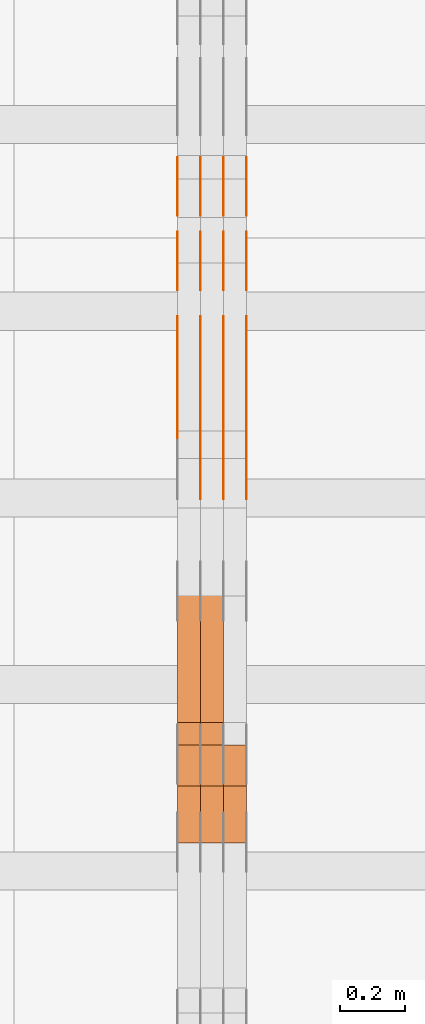
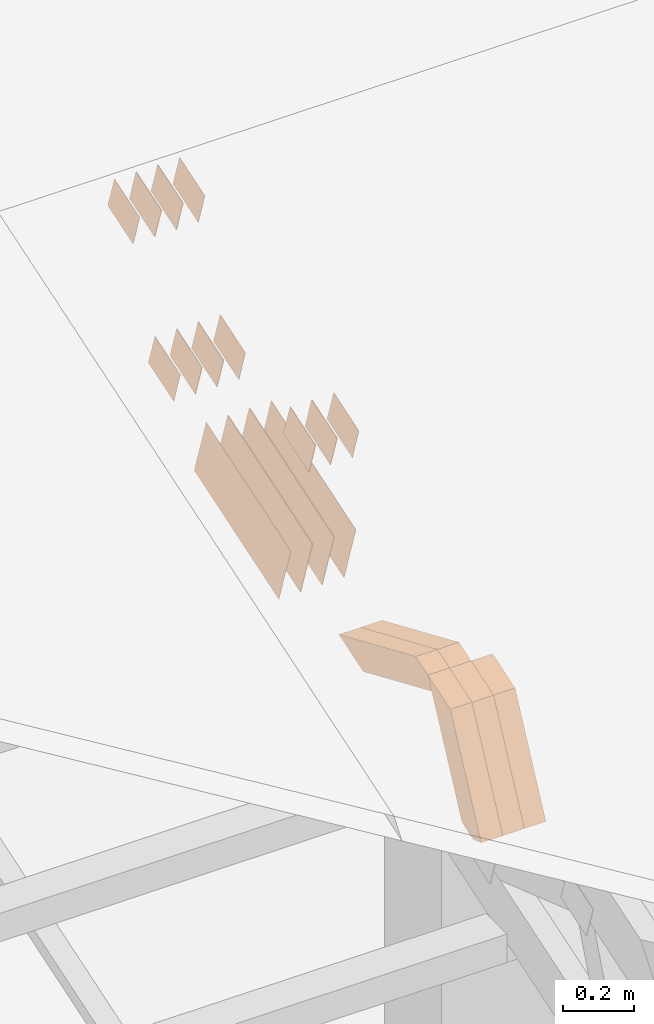
# One storey, part 64 of 385: 28 proxies.
"""IFC2X3 building model written with IfcOpenShell, lengths in millimetres."""

import ifcopenshell
import ifcopenshell.guid

model = None  # the IFC model being written
_history = None  # IfcOwnerHistory: only IFC2X3 demands one
_inside = {}  # id of a spatial element -> (the spatial element, [elements in it])
_under = {}  # id of a project, library or spatial element -> (it, [spatial elements below it])
_declared = {}  # id of a project -> (the project, [libraries it declares])
_typed = {}  # id of a type object -> (the type object, [elements of that type])
_made_of = {}  # id of a material, layer set ... -> (it, [elements and type objects made of it])


def new_model(schema):
    """Start an empty IFC model of exactly this schema.

    Asked for "IFC4X3", IfcOpenShell would pick the latest addendum, in which some entities
    have other attributes; the version numbers below select the first issue.
    IFC2X3 requires an IfcOwnerHistory on every rooted entity: one is made here for all.
    """
    global model, _history
    if schema == "IFC4X3":
        model = ifcopenshell.file(schema_version=(4, 3, 0, 0))
    else:
        model = ifcopenshell.file(schema=schema)
    _inside.clear()
    _under.clear()
    _declared.clear()
    _typed.clear()
    _made_of.clear()
    _history = None
    if model.schema == "IFC2X3":
        org = make("IfcOrganization", Name="unknown")
        user = make(
            "IfcPersonAndOrganization",
            ThePerson=make("IfcPerson", FamilyName="unknown"),
            TheOrganization=org,
        )
        app = make(
            "IfcApplication",
            ApplicationDeveloper=org,
            Version="unknown",
            ApplicationFullName="unknown",
            ApplicationIdentifier="unknown",
        )
        _history = make(
            "IfcOwnerHistory",
            OwningUser=user,
            OwningApplication=app,
            ChangeAction="ADDED",
            CreationDate=0,
        )
    return model


def make(cls, **values):
    """One entity of the class cls with the attributes given. An attribute that is None is left unset."""
    return model.create_entity(
        cls, **{name: value for name, value in values.items() if value is not None}
    )


def entity(cls, *values):
    """Any entity or typed value of the class cls, its attributes in the order of the schema. None: left unset."""
    e = model.create_entity(cls)
    for i, value in enumerate(values):
        if value is not None:
            e[i] = value
    return e


def rooted(cls, **values):
    """An entity with a GlobalId (a new one), such as an element, a storey or a relation."""
    return make(cls, GlobalId=ifcopenshell.guid.new(), OwnerHistory=_history, **values)


def si_unit(unit_type, name, prefix=None):
    """IfcSIUnit, for example si_unit("LENGTHUNIT", "METRE", prefix="MILLI")."""
    return make("IfcSIUnit", UnitType=unit_type, Prefix=prefix, Name=name)


def converted_unit(unit_type, name, factor, base, dimensions=None, offset=None):
    """IfcConversionBasedUnit, such as the inch: factor (a typed value) times the base unit."""
    return make(
        "IfcConversionBasedUnit"
        if offset is None
        else "IfcConversionBasedUnitWithOffset",
        ConversionOffset=offset,
        Dimensions=None
        if dimensions is None
        else entity("IfcDimensionalExponents", *dimensions),
        UnitType=unit_type,
        Name=name,
        ConversionFactor=make(
            "IfcMeasureWithUnit", ValueComponent=factor, UnitComponent=base
        ),
    )


def derived_unit(unit_type, elements):
    """IfcDerivedUnit: a product of units, each with its exponent."""
    return make(
        "IfcDerivedUnit",
        Elements=[
            make("IfcDerivedUnitElement", Unit=unit, Exponent=power)
            for unit, power in elements
        ],
        UnitType=unit_type,
    )


def assignment(units):
    """IfcUnitAssignment: the units of a project."""
    return None if units is None else make("IfcUnitAssignment", Units=units)


def point(xyz):
    """IfcCartesianPoint."""
    return None if xyz is None else make("IfcCartesianPoint", Coordinates=xyz)


def direction(xyz):
    """IfcDirection."""
    return None if xyz is None else make("IfcDirection", DirectionRatios=xyz)


def frame(location, z_axis=None, x_axis=None):
    """IfcAxis2Placement3D, a coordinate frame: its origin and axes. An axis left out is left unset."""
    return make(
        "IfcAxis2Placement3D",
        Location=point(location),
        Axis=direction(z_axis),
        RefDirection=direction(x_axis),
    )


def origin():
    """The frame at (0, 0, 0) with its axes left unset."""
    return frame((0.0, 0.0, 0.0))


def place(relative_to, where):
    """IfcLocalPlacement: puts the frame where relative to a parent placement (None: the world)."""
    return make(
        "IfcLocalPlacement", PlacementRelTo=relative_to, RelativePlacement=where
    )


def context(
    kind, dimensions, precision=None, world=None, true_north=None, identifier=None
):
    """IfcGeometricRepresentationContext, for example the 3D "Model" context."""
    return make(
        "IfcGeometricRepresentationContext",
        ContextIdentifier=identifier,
        ContextType=kind,
        CoordinateSpaceDimension=dimensions,
        Precision=precision,
        WorldCoordinateSystem=world,
        TrueNorth=true_north,
    )


def subcontext(parent, identifier, kind, view, scale=None):
    """IfcGeometricRepresentationSubContext, for example "Body" below "Model"."""
    return make(
        "IfcGeometricRepresentationSubContext",
        ContextIdentifier=identifier,
        ContextType=kind,
        ParentContext=parent,
        TargetScale=scale,
        TargetView=view,
    )


def project(units=None, contexts=None):
    """IfcProject with its units and contexts."""
    return rooted(
        "IfcProject",
        Name="project",
        RepresentationContexts=contexts,
        UnitsInContext=assignment(units),
    )


def spatial(cls, under=None, at=None, **own):
    """A site, building, storey or space (cls), placed at a placement, below another one or the project."""
    s = rooted(cls, ObjectPlacement=at, **own)
    if under is not None:
        _under.setdefault(under.id(), (under, []))[1].append(s)
    return s


def polyline(points):
    """IfcPolyline through the points."""
    return make("IfcPolyline", Points=[point(p) for p in points])


def outline(outer, holes=None, kind="AREA"):
    """IfcArbitraryClosedProfileDef: a profile drawn as a closed curve; with holes, ...WithVoids."""
    if holes is None:
        return make("IfcArbitraryClosedProfileDef", ProfileType=kind, OuterCurve=outer)
    return make(
        "IfcArbitraryProfileDefWithVoids",
        ProfileType=kind,
        OuterCurve=outer,
        InnerCurves=holes,
    )


def extrude(swept, where, along, depth):
    """IfcExtrudedAreaSolid: the profile swept, set in the frame where, extruded along a direction by depth."""
    return make(
        "IfcExtrudedAreaSolid",
        SweptArea=swept,
        Position=where,
        ExtrudedDirection=direction(along),
        Depth=depth,
    )


def shape(context_of_items, identifier, shape_type, items):
    """IfcShapeRepresentation: the items that make up one representation, for example the "Body"."""
    return make(
        "IfcShapeRepresentation",
        ContextOfItems=context_of_items,
        RepresentationIdentifier=identifier,
        RepresentationType=shape_type,
        Items=items,
    )


def source(mapping_origin, context_of_items, identifier, shape_type, items):
    """IfcRepresentationMap: a shape defined once, which mapped items show again and again."""
    return make(
        "IfcRepresentationMap",
        MappingOrigin=mapping_origin,
        MappedRepresentation=shape(context_of_items, identifier, shape_type, items),
    )


def transform(
    local_origin,
    x_axis=None,
    y_axis=None,
    z_axis=None,
    scale=None,
    scale2=None,
    scale3=None,
    uniform=True,
):
    """IfcCartesianTransformationOperator3D, or its non-uniform kind. x_axis, y_axis, z_axis: its Axis1, 2, 3."""
    if uniform:
        return make(
            "IfcCartesianTransformationOperator3D",
            Axis1=direction(x_axis),
            Axis2=direction(y_axis),
            LocalOrigin=point(local_origin),
            Scale=scale,
            Axis3=direction(z_axis),
        )
    return make(
        "IfcCartesianTransformationOperator3DnonUniform",
        Axis1=direction(x_axis),
        Axis2=direction(y_axis),
        LocalOrigin=point(local_origin),
        Scale=scale,
        Axis3=direction(z_axis),
        Scale2=scale2,
        Scale3=scale3,
    )


def mapped(mapping_source, mapping_target):
    """IfcMappedItem: shows the shape of a source again, moved by a transform."""
    return make(
        "IfcMappedItem", MappingSource=mapping_source, MappingTarget=mapping_target
    )


def material(Name=None, Category=None):
    """IfcMaterial."""
    return make("IfcMaterial", Name=Name, Category=Category)


def made_of(thing, what):
    """Note that an element or type object is made of a material, layer set ...; save() writes the relation."""
    if what is not None:
        _made_of.setdefault(what.id(), (what, []))[1].append(thing)
    return thing


def type_object(cls, material=None, **own):
    """A type object (cls), such as IfcWallType, which elements share."""
    return made_of(rooted(cls, **own), material)


def type_shapes(of_type, sources):
    """Give a type object the sources (RepresentationMaps) that its elements show as mapped items."""
    of_type.RepresentationMaps = sources


def element(
    cls,
    number,
    at=None,
    inside=None,
    cuts=None,
    type_object=None,
    material=None,
    context=None,
    identifier="Body",
    shape_type=None,
    held_by="IfcProductDefinitionShape",
    body=None,
    shapes=None,
    **own,
):
    """One element of the class cls, such as IfcWall. Its Tag is "e" and its number.

    at: its placement. inside: the storey or other place that contains it. cuts: it is an
    opening in that element (IfcRelVoidsElement). A single representation is given by context,
    identifier, shape_type and body (its items); several are given by shapes. held_by: the class
    of the entity that holds the representations. save() writes the other relations.
    """
    e = rooted(cls, Tag="e%d" % number, ObjectPlacement=at, **own)
    if body is not None:
        shapes = [shape(context, identifier, shape_type, body)]
    if shapes is not None:
        e.Representation = make(held_by, Representations=shapes)
    if inside is not None:
        _inside.setdefault(inside.id(), (inside, []))[1].append(e)
    if cuts is not None:
        rooted(
            "IfcRelVoidsElement", RelatingBuildingElement=cuts, RelatedOpeningElement=e
        )
    if type_object is not None:
        _typed.setdefault(type_object.id(), (type_object, []))[1].append(e)
    return made_of(e, material)


def aggregate(whole, parts):
    """IfcRelAggregates: a whole, such as a stair, and the parts it consists of."""
    return rooted("IfcRelAggregates", RelatingObject=whole, RelatedObjects=parts)


def save(model, path):
    """Write the relations noted so far, then the file.

    IfcRelAggregates (storeys below a building ...), IfcRelContainedInSpatialStructure (elements
    in a storey), IfcRelDefinesByType, IfcRelAssociatesMaterial and IfcRelDeclares: one each for
    every whole, place, type object, material and project.
    """
    for whole, parts in _under.values():
        aggregate(whole, parts)
    for where, things in _inside.values():
        rooted(
            "IfcRelContainedInSpatialStructure",
            RelatedElements=things,
            RelatingStructure=where,
        )
    for kind, things in _typed.values():
        rooted("IfcRelDefinesByType", RelatedObjects=things, RelatingType=kind)
    for what, things in _made_of.values():
        rooted("IfcRelAssociatesMaterial", RelatedObjects=things, RelatingMaterial=what)
    for by, libraries in _declared.values():
        rooted("IfcRelDeclares", RelatingContext=by, RelatedDefinitions=libraries)
    model.write(path)


model = new_model("IFC2X3")

# Units and contexts
model_context = context("Model", 3, precision=0.01, world=origin(), true_north=direction((6.12303176911189e-17, 1.0)))
body_context = subcontext(model_context, "Body", "Model", "MODEL_VIEW")
ifc_project = project(units=[si_unit("LENGTHUNIT", "METRE", prefix="MILLI"), si_unit("AREAUNIT", "SQUARE_METRE"), si_unit("VOLUMEUNIT", "CUBIC_METRE"), converted_unit("PLANEANGLEUNIT", "DEGREE", entity("IfcRatioMeasure", 0.0174532925199433), si_unit("PLANEANGLEUNIT", "RADIAN"), dimensions=[0, 0, 0, 0, 0, 0, 0]), si_unit("MASSUNIT", "GRAM", prefix="KILO"), derived_unit("MASSDENSITYUNIT", [(si_unit("MASSUNIT", "GRAM", prefix="KILO"), 1), (si_unit("LENGTHUNIT", "METRE"), -3)]), si_unit("TIMEUNIT", "SECOND"), si_unit("FREQUENCYUNIT", "HERTZ"), si_unit("THERMODYNAMICTEMPERATUREUNIT", "DEGREE_CELSIUS"), derived_unit("THERMALTRANSMITTANCEUNIT", [(si_unit("MASSUNIT", "GRAM", prefix="KILO"), 1), (si_unit("THERMODYNAMICTEMPERATUREUNIT", "KELVIN"), -1), (si_unit("TIMEUNIT", "SECOND"), -3)]), derived_unit("VOLUMETRICFLOWRATEUNIT", [(si_unit("LENGTHUNIT", "METRE"), 3), (si_unit("TIMEUNIT", "SECOND"), -1)]), si_unit("ELECTRICCURRENTUNIT", "AMPERE"), si_unit("ELECTRICVOLTAGEUNIT", "VOLT"), si_unit("POWERUNIT", "WATT"), si_unit("FORCEUNIT", "NEWTON", prefix="KILO"), si_unit("ILLUMINANCEUNIT", "LUX"), si_unit("LUMINOUSFLUXUNIT", "LUMEN"), si_unit("LUMINOUSINTENSITYUNIT", "CANDELA"), derived_unit("USERDEFINED", [(si_unit("MASSUNIT", "GRAM", prefix="KILO"), -1), (si_unit("LENGTHUNIT", "METRE"), -2), (si_unit("TIMEUNIT", "SECOND"), 3), (si_unit("LUMINOUSFLUXUNIT", "LUMEN"), 1)]), derived_unit("LINEARVELOCITYUNIT", [(si_unit("LENGTHUNIT", "METRE"), 1), (si_unit("TIMEUNIT", "SECOND"), -1)]), si_unit("PRESSUREUNIT", "PASCAL"), derived_unit("USERDEFINED", [(si_unit("LENGTHUNIT", "METRE"), -2), (si_unit("MASSUNIT", "GRAM", prefix="KILO"), 1), (si_unit("TIMEUNIT", "SECOND"), -2)])], contexts=[model_context])

# Site, building, storey
site_placement = place(None, origin())
site = spatial("IfcSite", under=ifc_project, at=site_placement, CompositionType="ELEMENT")
building_placement = place(site_placement, origin())
building = spatial("IfcBuilding", under=site, at=building_placement, CompositionType="ELEMENT")
storey_placement = place(building_placement, origin())
storey = spatial("IfcBuildingStorey", under=building, at=storey_placement, Name="Default", CompositionType="ELEMENT", Elevation=0.0)

# Proxies
ifc_material_1 = material(Name="IfcSurfaceStyle #144038")
building_element_proxy_type_1 = type_object("IfcBuildingElementProxyType", PredefinedType="NOTDEFINED", material=ifc_material_1)
shared_shape_1 = source(origin(), body_context, "Body", "SweptSolid", [
    extrude(outline(polyline([(-74.9998565677179, -60.000059685226), (74.9998794200128, -60.000059685226), (74.9998565677179, 60.000059685226), (-74.9998794200128, 60.000059685226), (-74.9998565677179, -60.000059685226)])), frame((75.0001976720505, 60.000059685226, 0.0), z_axis=(0.0, 0.0, 1.0), x_axis=(-1.0, 0.0, 0.0)), (0.0, 0.0, 1.0), 1.3),
])
type_shapes(building_element_proxy_type_1, [shared_shape_1])
proxy_1_placement = place(building_placement, frame((9386.29999999998, 8537.53090236182, 1950.11166041942), z_axis=(-1.0, 0.0, 0.0), x_axis=(0.0, 0.951056516295124, 0.309016994375039)))
element("IfcBuildingElementProxy", 1, at=proxy_1_placement, inside=storey, type_object=building_element_proxy_type_1, material=ifc_material_1, context=body_context, shape_type="MappedRepresentation", body=[
    mapped(shared_shape_1, transform((0.0, 0.0, 0.0), scale=1.0)),
])
ifc_material_2 = material(Name="IfcSurfaceStyle #143981")
building_element_proxy_type_2 = type_object("IfcBuildingElementProxyType", PredefinedType="NOTDEFINED", material=ifc_material_2)
shared_shape_2 = source(origin(), body_context, "Body", "SweptSolid", [
    extrude(outline(polyline([(-74.9998565677179, -60.000059685226), (74.9998794200128, -60.000059685226), (74.9998565677179, 60.000059685226), (-74.9998794200128, 60.000059685226), (-74.9998565677179, -60.000059685226)])), frame((75.0001976720505, 60.000059685226, 0.0), z_axis=(0.0, 0.0, 1.0), x_axis=(-1.0, 0.0, 0.0)), (0.0, 0.0, 1.0), 1.3),
])
type_shapes(building_element_proxy_type_2, [shared_shape_2])
proxy_2_placement = place(building_placement, frame((9315.0, 8537.53090236182, 1950.11166041942), z_axis=(-1.0, 0.0, 0.0), x_axis=(0.0, 0.951056516295124, 0.309016994375039)))
element("IfcBuildingElementProxy", 2, at=proxy_2_placement, inside=storey, type_object=building_element_proxy_type_2, material=ifc_material_2, context=body_context, shape_type="MappedRepresentation", body=[
    mapped(shared_shape_2, transform((0.0, 0.0, 0.0), scale=1.0)),
])
ifc_material_3 = material(Name="IfcSurfaceStyle #143924")
building_element_proxy_type_3 = type_object("IfcBuildingElementProxyType", PredefinedType="NOTDEFINED", material=ifc_material_3)
shared_shape_3 = source(origin(), body_context, "Body", "SweptSolid", [
    extrude(outline(polyline([(-74.9998565677179, -60.000059685226), (74.9998794200128, -60.000059685226), (74.9998565677179, 60.000059685226), (-74.9998794200128, 60.000059685226), (-74.9998565677179, -60.000059685226)])), frame((75.0001976720505, 60.000059685226, 0.0), z_axis=(0.0, 0.0, 1.0), x_axis=(-1.0, 0.0, 0.0)), (0.0, 0.0, 1.0), 1.3),
])
type_shapes(building_element_proxy_type_3, [shared_shape_3])
proxy_3_placement = place(building_placement, frame((9316.29999999998, 8537.53090236182, 1950.11166041942), z_axis=(-1.0, 0.0, 0.0), x_axis=(0.0, 0.951056516295124, 0.309016994375039)))
element("IfcBuildingElementProxy", 3, at=proxy_3_placement, inside=storey, type_object=building_element_proxy_type_3, material=ifc_material_3, context=body_context, shape_type="MappedRepresentation", body=[
    mapped(shared_shape_3, transform((0.0, 0.0, 0.0), scale=1.0)),
])
ifc_material_4 = material(Name="IfcSurfaceStyle #143867")
building_element_proxy_type_4 = type_object("IfcBuildingElementProxyType", PredefinedType="NOTDEFINED", material=ifc_material_4)
shared_shape_4 = source(origin(), body_context, "Body", "SweptSolid", [
    extrude(outline(polyline([(-74.9998565677179, -60.000059685226), (74.9998794200128, -60.000059685226), (74.9998565677179, 60.000059685226), (-74.9998794200128, 60.000059685226), (-74.9998565677179, -60.000059685226)])), frame((75.0001976720505, 60.000059685226, 0.0), z_axis=(0.0, 0.0, 1.0), x_axis=(-1.0, 0.0, 0.0)), (0.0, 0.0, 1.0), 1.29999999999999),
])
type_shapes(building_element_proxy_type_4, [shared_shape_4])
proxy_4_placement = place(building_placement, frame((9245.0, 8537.53090236182, 1950.11166041942), z_axis=(-1.0, 0.0, 0.0), x_axis=(0.0, 0.951056516295124, 0.309016994375039)))
element("IfcBuildingElementProxy", 4, at=proxy_4_placement, inside=storey, type_object=building_element_proxy_type_4, material=ifc_material_4, context=body_context, shape_type="MappedRepresentation", body=[
    mapped(shared_shape_4, transform((0.0, 0.0, 0.0), scale=1.0)),
])
ifc_material_5 = material(Name="IfcSurfaceStyle #143810")
building_element_proxy_type_5 = type_object("IfcBuildingElementProxyType", PredefinedType="NOTDEFINED", material=ifc_material_5)
shared_shape_5 = source(origin(), body_context, "Body", "SweptSolid", [
    extrude(outline(polyline([(-74.9998565677179, -60.000059685226), (74.9998794200128, -60.000059685226), (74.9998565677179, 60.000059685226), (-74.9998794200128, 60.000059685226), (-74.9998565677179, -60.000059685226)])), frame((75.0001976720505, 60.000059685226, 0.0), z_axis=(0.0, 0.0, 1.0), x_axis=(-1.0, 0.0, 0.0)), (0.0, 0.0, 1.0), 1.29999999999999),
])
type_shapes(building_element_proxy_type_5, [shared_shape_5])
proxy_5_placement = place(building_placement, frame((9246.29999999998, 8537.53090236182, 1950.11166041942), z_axis=(-1.0, 0.0, 0.0), x_axis=(0.0, 0.951056516295124, 0.309016994375039)))
element("IfcBuildingElementProxy", 5, at=proxy_5_placement, inside=storey, type_object=building_element_proxy_type_5, material=ifc_material_5, context=body_context, shape_type="MappedRepresentation", body=[
    mapped(shared_shape_5, transform((0.0, 0.0, 0.0), scale=1.0)),
])
ifc_material_6 = material(Name="IfcSurfaceStyle #143753")
building_element_proxy_type_6 = type_object("IfcBuildingElementProxyType", PredefinedType="NOTDEFINED", material=ifc_material_6)
shared_shape_6 = source(origin(), body_context, "Body", "SweptSolid", [
    extrude(outline(polyline([(-74.9998565677179, -60.000059685226), (74.9998794200128, -60.000059685226), (74.9998565677179, 60.000059685226), (-74.9998794200128, 60.000059685226), (-74.9998565677179, -60.000059685226)])), frame((75.0001976720505, 60.000059685226, 0.0), z_axis=(0.0, 0.0, 1.0), x_axis=(-1.0, 0.0, 0.0)), (0.0, 0.0, 1.0), 1.29999999999999),
])
type_shapes(building_element_proxy_type_6, [shared_shape_6])
proxy_6_placement = place(building_placement, frame((9175.0, 8537.53090236182, 1950.11166041942), z_axis=(-1.0, 0.0, 0.0), x_axis=(0.0, 0.951056516295124, 0.309016994375039)))
element("IfcBuildingElementProxy", 6, at=proxy_6_placement, inside=storey, type_object=building_element_proxy_type_6, material=ifc_material_6, context=body_context, shape_type="MappedRepresentation", body=[
    mapped(shared_shape_6, transform((0.0, 0.0, 0.0), scale=1.0)),
])
ifc_material_7 = material(Name="IfcSurfaceStyle #143696")
building_element_proxy_type_7 = type_object("IfcBuildingElementProxyType", PredefinedType="NOTDEFINED", material=ifc_material_7)
shared_shape_7 = source(origin(), body_context, "Body", "SweptSolid", [
    extrude(outline(polyline([(-74.9998754286225, -60.0000016373515), (74.9998605591045, -60.0000016373515), (74.9998754286225, 60.0000016373515), (-74.9998605591045, 60.0000016373515), (-74.9998754286225, -60.0000016373515)])), frame((74.9998754286225, 60.0000016373515, 0.0), z_axis=(0.0, 0.0, 1.0), x_axis=(-1.0, 0.0, 0.0)), (0.0, 0.0, 1.0), 1.3),
])
type_shapes(building_element_proxy_type_7, [shared_shape_7])
proxy_7_placement = place(building_placement, frame((9386.29999999998, 8765.47458614632, 2350.86432930304), z_axis=(-1.0, 0.0, 0.0), x_axis=(0.0, 0.951056516295154, 0.309016994374948)))
element("IfcBuildingElementProxy", 7, at=proxy_7_placement, inside=storey, type_object=building_element_proxy_type_7, material=ifc_material_7, context=body_context, shape_type="MappedRepresentation", body=[
    mapped(shared_shape_7, transform((0.0, 0.0, 0.0), scale=1.0)),
])
ifc_material_8 = material(Name="IfcSurfaceStyle #143639")
building_element_proxy_type_8 = type_object("IfcBuildingElementProxyType", PredefinedType="NOTDEFINED", material=ifc_material_8)
shared_shape_8 = source(origin(), body_context, "Body", "SweptSolid", [
    extrude(outline(polyline([(-74.9998754286225, -60.0000016373515), (74.9998605591045, -60.0000016373515), (74.9998754286225, 60.0000016373515), (-74.9998605591045, 60.0000016373515), (-74.9998754286225, -60.0000016373515)])), frame((74.9998754286225, 60.0000016373515, 0.0), z_axis=(0.0, 0.0, 1.0), x_axis=(-1.0, 0.0, 0.0)), (0.0, 0.0, 1.0), 1.3),
])
type_shapes(building_element_proxy_type_8, [shared_shape_8])
proxy_8_placement = place(building_placement, frame((9315.0, 8765.47458614632, 2350.86432930304), z_axis=(-1.0, 0.0, 0.0), x_axis=(0.0, 0.951056516295154, 0.309016994374948)))
element("IfcBuildingElementProxy", 8, at=proxy_8_placement, inside=storey, type_object=building_element_proxy_type_8, material=ifc_material_8, context=body_context, shape_type="MappedRepresentation", body=[
    mapped(shared_shape_8, transform((0.0, 0.0, 0.0), scale=1.0)),
])
ifc_material_9 = material(Name="IfcSurfaceStyle #143582")
building_element_proxy_type_9 = type_object("IfcBuildingElementProxyType", PredefinedType="NOTDEFINED", material=ifc_material_9)
shared_shape_9 = source(origin(), body_context, "Body", "SweptSolid", [
    extrude(outline(polyline([(-74.9998754286225, -60.0000016373515), (74.9998605591045, -60.0000016373515), (74.9998754286225, 60.0000016373515), (-74.9998605591045, 60.0000016373515), (-74.9998754286225, -60.0000016373515)])), frame((74.9998754286225, 60.0000016373515, 0.0), z_axis=(0.0, 0.0, 1.0), x_axis=(-1.0, 0.0, 0.0)), (0.0, 0.0, 1.0), 1.3),
])
type_shapes(building_element_proxy_type_9, [shared_shape_9])
proxy_9_placement = place(building_placement, frame((9316.29999999998, 8765.47458614632, 2350.86432930304), z_axis=(-1.0, 0.0, 0.0), x_axis=(0.0, 0.951056516295154, 0.309016994374948)))
element("IfcBuildingElementProxy", 9, at=proxy_9_placement, inside=storey, type_object=building_element_proxy_type_9, material=ifc_material_9, context=body_context, shape_type="MappedRepresentation", body=[
    mapped(shared_shape_9, transform((0.0, 0.0, 0.0), scale=1.0)),
])
ifc_material_10 = material(Name="IfcSurfaceStyle #143525")
building_element_proxy_type_10 = type_object("IfcBuildingElementProxyType", PredefinedType="NOTDEFINED", material=ifc_material_10)
shared_shape_10 = source(origin(), body_context, "Body", "SweptSolid", [
    extrude(outline(polyline([(-74.9998754286225, -60.0000016373515), (74.9998605591045, -60.0000016373515), (74.9998754286225, 60.0000016373515), (-74.9998605591045, 60.0000016373515), (-74.9998754286225, -60.0000016373515)])), frame((74.9998754286225, 60.0000016373515, 0.0), z_axis=(0.0, 0.0, 1.0), x_axis=(-1.0, 0.0, 0.0)), (0.0, 0.0, 1.0), 1.29999999999999),
])
type_shapes(building_element_proxy_type_10, [shared_shape_10])
proxy_10_placement = place(building_placement, frame((9245.0, 8765.47458614632, 2350.86432930304), z_axis=(-1.0, 0.0, 0.0), x_axis=(0.0, 0.951056516295154, 0.309016994374948)))
element("IfcBuildingElementProxy", 10, at=proxy_10_placement, inside=storey, type_object=building_element_proxy_type_10, material=ifc_material_10, context=body_context, shape_type="MappedRepresentation", body=[
    mapped(shared_shape_10, transform((0.0, 0.0, 0.0), scale=1.0)),
])
ifc_material_11 = material(Name="IfcSurfaceStyle #143468")
building_element_proxy_type_11 = type_object("IfcBuildingElementProxyType", PredefinedType="NOTDEFINED", material=ifc_material_11)
shared_shape_11 = source(origin(), body_context, "Body", "SweptSolid", [
    extrude(outline(polyline([(-74.9998754286225, -60.0000016373515), (74.9998605591045, -60.0000016373515), (74.9998754286225, 60.0000016373515), (-74.9998605591045, 60.0000016373515), (-74.9998754286225, -60.0000016373515)])), frame((74.9998754286225, 60.0000016373515, 0.0), z_axis=(0.0, 0.0, 1.0), x_axis=(-1.0, 0.0, 0.0)), (0.0, 0.0, 1.0), 1.29999999999999),
])
type_shapes(building_element_proxy_type_11, [shared_shape_11])
proxy_11_placement = place(building_placement, frame((9246.29999999998, 8765.47458614632, 2350.86432930304), z_axis=(-1.0, 0.0, 0.0), x_axis=(0.0, 0.951056516295154, 0.309016994374948)))
element("IfcBuildingElementProxy", 11, at=proxy_11_placement, inside=storey, type_object=building_element_proxy_type_11, material=ifc_material_11, context=body_context, shape_type="MappedRepresentation", body=[
    mapped(shared_shape_11, transform((0.0, 0.0, 0.0), scale=1.0)),
])
ifc_material_12 = material(Name="IfcSurfaceStyle #143411")
building_element_proxy_type_12 = type_object("IfcBuildingElementProxyType", PredefinedType="NOTDEFINED", material=ifc_material_12)
shared_shape_12 = source(origin(), body_context, "Body", "SweptSolid", [
    extrude(outline(polyline([(-74.9998754286225, -60.0000016373515), (74.9998605591045, -60.0000016373515), (74.9998754286225, 60.0000016373515), (-74.9998605591045, 60.0000016373515), (-74.9998754286225, -60.0000016373515)])), frame((74.9998754286225, 60.0000016373515, 0.0), z_axis=(0.0, 0.0, 1.0), x_axis=(-1.0, 0.0, 0.0)), (0.0, 0.0, 1.0), 1.29999999999999),
])
type_shapes(building_element_proxy_type_12, [shared_shape_12])
proxy_12_placement = place(building_placement, frame((9175.0, 8765.47458614632, 2350.86432930304), z_axis=(-1.0, 0.0, 0.0), x_axis=(0.0, 0.951056516295154, 0.309016994374948)))
element("IfcBuildingElementProxy", 12, at=proxy_12_placement, inside=storey, type_object=building_element_proxy_type_12, material=ifc_material_12, context=body_context, shape_type="MappedRepresentation", body=[
    mapped(shared_shape_12, transform((0.0, 0.0, 0.0), scale=1.0)),
])
ifc_material_13 = material(Name="IfcSurfaceStyle #143012")
building_element_proxy_type_13 = type_object("IfcBuildingElementProxyType", PredefinedType="NOTDEFINED", material=ifc_material_13)
shared_shape_13 = source(origin(), body_context, "Body", "SweptSolid", [
    extrude(outline(polyline([(-249.999749056184, -108.000229288163), (249.999396050782, -108.000229288163), (249.999749056184, 108.000229288163), (-249.999396050782, 108.000229288163), (-249.999749056184, -108.000229288163)])), frame((249.999841104007, 108.000229288163, 0.0), z_axis=(0.0, 0.0, 1.0), x_axis=(-1.0, 0.0, 0.0)), (0.0, 0.0, 1.0), 1.29999999999998),
])
type_shapes(building_element_proxy_type_13, [shared_shape_13])
proxy_13_placement = place(building_placement, frame((9386.29999999998, 7917.13457673635, 1720.66532252899), z_axis=(-1.0, 0.0, 0.0), x_axis=(0.0, 0.951056516295124, 0.309016994375039)))
element("IfcBuildingElementProxy", 13, at=proxy_13_placement, inside=storey, type_object=building_element_proxy_type_13, material=ifc_material_13, context=body_context, shape_type="MappedRepresentation", body=[
    mapped(shared_shape_13, transform((0.0, 0.0, 0.0), scale=1.0)),
])
ifc_material_14 = material(Name="IfcSurfaceStyle #142955")
building_element_proxy_type_14 = type_object("IfcBuildingElementProxyType", PredefinedType="NOTDEFINED", material=ifc_material_14)
shared_shape_14 = source(origin(), body_context, "Body", "SweptSolid", [
    extrude(outline(polyline([(-249.999749056184, -108.000229288163), (249.999396050782, -108.000229288163), (249.999749056184, 108.000229288163), (-249.999396050782, 108.000229288163), (-249.999749056184, -108.000229288163)])), frame((249.999841104007, 108.000229288163, 0.0), z_axis=(0.0, 0.0, 1.0), x_axis=(-1.0, 0.0, 0.0)), (0.0, 0.0, 1.0), 1.29999999999998),
])
type_shapes(building_element_proxy_type_14, [shared_shape_14])
proxy_14_placement = place(building_placement, frame((9315.0, 7917.13457673635, 1720.66532252899), z_axis=(-1.0, 0.0, 0.0), x_axis=(0.0, 0.951056516295124, 0.309016994375039)))
element("IfcBuildingElementProxy", 14, at=proxy_14_placement, inside=storey, type_object=building_element_proxy_type_14, material=ifc_material_14, context=body_context, shape_type="MappedRepresentation", body=[
    mapped(shared_shape_14, transform((0.0, 0.0, 0.0), scale=1.0)),
])
ifc_material_15 = material(Name="IfcSurfaceStyle #142898")
building_element_proxy_type_15 = type_object("IfcBuildingElementProxyType", PredefinedType="NOTDEFINED", material=ifc_material_15)
shared_shape_15 = source(origin(), body_context, "Body", "SweptSolid", [
    extrude(outline(polyline([(-249.999749056184, -108.000229288163), (249.999396050782, -108.000229288163), (249.999749056184, 108.000229288163), (-249.999396050782, 108.000229288163), (-249.999749056184, -108.000229288163)])), frame((249.999841104007, 108.000229288163, 0.0), z_axis=(0.0, 0.0, 1.0), x_axis=(-1.0, 0.0, 0.0)), (0.0, 0.0, 1.0), 1.29999999999998),
])
type_shapes(building_element_proxy_type_15, [shared_shape_15])
proxy_15_placement = place(building_placement, frame((9316.29999999998, 7917.13457673635, 1720.66532252899), z_axis=(-1.0, 0.0, 0.0), x_axis=(0.0, 0.951056516295124, 0.309016994375039)))
element("IfcBuildingElementProxy", 15, at=proxy_15_placement, inside=storey, type_object=building_element_proxy_type_15, material=ifc_material_15, context=body_context, shape_type="MappedRepresentation", body=[
    mapped(shared_shape_15, transform((0.0, 0.0, 0.0), scale=1.0)),
])
ifc_material_16 = material(Name="IfcSurfaceStyle #142841")
building_element_proxy_type_16 = type_object("IfcBuildingElementProxyType", PredefinedType="NOTDEFINED", material=ifc_material_16)
shared_shape_16 = source(origin(), body_context, "Body", "SweptSolid", [
    extrude(outline(polyline([(-249.999749056184, -108.000229288163), (249.999396050782, -108.000229288163), (249.999749056184, 108.000229288163), (-249.999396050782, 108.000229288163), (-249.999749056184, -108.000229288163)])), frame((249.999841104007, 108.000229288163, 0.0), z_axis=(0.0, 0.0, 1.0), x_axis=(-1.0, 0.0, 0.0)), (0.0, 0.0, 1.0), 1.29999999999997),
])
type_shapes(building_element_proxy_type_16, [shared_shape_16])
proxy_16_placement = place(building_placement, frame((9245.0, 7917.13457673635, 1720.66532252899), z_axis=(-1.0, 0.0, 0.0), x_axis=(0.0, 0.951056516295124, 0.309016994375039)))
element("IfcBuildingElementProxy", 16, at=proxy_16_placement, inside=storey, type_object=building_element_proxy_type_16, material=ifc_material_16, context=body_context, shape_type="MappedRepresentation", body=[
    mapped(shared_shape_16, transform((0.0, 0.0, 0.0), scale=1.0)),
])
ifc_material_17 = material(Name="IfcSurfaceStyle #142784")
building_element_proxy_type_17 = type_object("IfcBuildingElementProxyType", PredefinedType="NOTDEFINED", material=ifc_material_17)
shared_shape_17 = source(origin(), body_context, "Body", "SweptSolid", [
    extrude(outline(polyline([(-249.999749056184, -108.000229288163), (249.999396050782, -108.000229288163), (249.999749056184, 108.000229288163), (-249.999396050782, 108.000229288163), (-249.999749056184, -108.000229288163)])), frame((249.999841104007, 108.000229288163, 0.0), z_axis=(0.0, 0.0, 1.0), x_axis=(-1.0, 0.0, 0.0)), (0.0, 0.0, 1.0), 1.29999999999997),
])
type_shapes(building_element_proxy_type_17, [shared_shape_17])
proxy_17_placement = place(building_placement, frame((9246.29999999998, 7917.13457673635, 1720.66532252899), z_axis=(-1.0, 0.0, 0.0), x_axis=(0.0, 0.951056516295124, 0.309016994375039)))
element("IfcBuildingElementProxy", 17, at=proxy_17_placement, inside=storey, type_object=building_element_proxy_type_17, material=ifc_material_17, context=body_context, shape_type="MappedRepresentation", body=[
    mapped(shared_shape_17, transform((0.0, 0.0, 0.0), scale=1.0)),
])
ifc_material_18 = material(Name="IfcSurfaceStyle #142727")
building_element_proxy_type_18 = type_object("IfcBuildingElementProxyType", PredefinedType="NOTDEFINED", material=ifc_material_18)
shared_shape_18 = source(origin(), body_context, "Body", "SweptSolid", [
    extrude(outline(polyline([(-249.999749056184, -108.000229288163), (249.999396050782, -108.000229288163), (249.999749056184, 108.000229288163), (-249.999396050782, 108.000229288163), (-249.999749056184, -108.000229288163)])), frame((249.999841104007, 108.000229288163, 0.0), z_axis=(0.0, 0.0, 1.0), x_axis=(-1.0, 0.0, 0.0)), (0.0, 0.0, 1.0), 1.29999999999997),
])
type_shapes(building_element_proxy_type_18, [shared_shape_18])
proxy_18_placement = place(building_placement, frame((9175.0, 7917.13457673635, 1720.66532252899), z_axis=(-1.0, 0.0, 0.0), x_axis=(0.0, 0.951056516295124, 0.309016994375039)))
element("IfcBuildingElementProxy", 18, at=proxy_18_placement, inside=storey, type_object=building_element_proxy_type_18, material=ifc_material_18, context=body_context, shape_type="MappedRepresentation", body=[
    mapped(shared_shape_18, transform((0.0, 0.0, 0.0), scale=1.0)),
])
ifc_material_19 = material(Name="IfcSurfaceStyle #129332")
building_element_proxy_type_19 = type_object("IfcBuildingElementProxyType", PredefinedType="NOTDEFINED", material=ifc_material_19)
shared_shape_19 = source(origin(), body_context, "Body", "SweptSolid", [
    extrude(outline(polyline([(-74.9998754286253, -60.0000016373506), (74.9998605591091, -60.0000016373506), (74.9998754286234, 60.0000016373506), (-74.9998605591072, 60.0000016373506), (-74.9998754286253, -60.0000016373506)])), frame((75.0007355357002, 60.0002637031812, 0.0), z_axis=(0.0, 0.0, 1.0), x_axis=(-1.0, 0.0, 0.0)), (0.0, 0.0, 1.0), 1.3),
])
type_shapes(building_element_proxy_type_19, [shared_shape_19])
proxy_19_placement = place(building_placement, frame((9386.29999999998, 7899.79204652809, 2069.58672486412), z_axis=(-1.0, 0.0, 0.0), x_axis=(0.0, 0.951056516295154, 0.309016994374948)))
element("IfcBuildingElementProxy", 19, at=proxy_19_placement, inside=storey, type_object=building_element_proxy_type_19, material=ifc_material_19, context=body_context, shape_type="MappedRepresentation", body=[
    mapped(shared_shape_19, transform((0.0, 0.0, 0.0), scale=1.0)),
])
ifc_material_20 = material(Name="IfcSurfaceStyle #129275")
building_element_proxy_type_20 = type_object("IfcBuildingElementProxyType", PredefinedType="NOTDEFINED", material=ifc_material_20)
shared_shape_20 = source(origin(), body_context, "Body", "SweptSolid", [
    extrude(outline(polyline([(-74.9998754286253, -60.0000016373506), (74.9998605591091, -60.0000016373506), (74.9998754286234, 60.0000016373506), (-74.9998605591072, 60.0000016373506), (-74.9998754286253, -60.0000016373506)])), frame((75.0007355357002, 60.0002637031812, 0.0), z_axis=(0.0, 0.0, 1.0), x_axis=(-1.0, 0.0, 0.0)), (0.0, 0.0, 1.0), 1.3),
])
type_shapes(building_element_proxy_type_20, [shared_shape_20])
proxy_20_placement = place(building_placement, frame((9315.0, 7899.79204652809, 2069.58672486412), z_axis=(-1.0, 0.0, 0.0), x_axis=(0.0, 0.951056516295154, 0.309016994374948)))
element("IfcBuildingElementProxy", 20, at=proxy_20_placement, inside=storey, type_object=building_element_proxy_type_20, material=ifc_material_20, context=body_context, shape_type="MappedRepresentation", body=[
    mapped(shared_shape_20, transform((0.0, 0.0, 0.0), scale=1.0)),
])
ifc_material_21 = material(Name="IfcSurfaceStyle #129218")
building_element_proxy_type_21 = type_object("IfcBuildingElementProxyType", PredefinedType="NOTDEFINED", material=ifc_material_21)
shared_shape_21 = source(origin(), body_context, "Body", "SweptSolid", [
    extrude(outline(polyline([(-74.9998754286253, -60.0000016373506), (74.9998605591091, -60.0000016373506), (74.9998754286234, 60.0000016373506), (-74.9998605591072, 60.0000016373506), (-74.9998754286253, -60.0000016373506)])), frame((75.0007355357002, 60.0002637031812, 0.0), z_axis=(0.0, 0.0, 1.0), x_axis=(-1.0, 0.0, 0.0)), (0.0, 0.0, 1.0), 1.3),
])
type_shapes(building_element_proxy_type_21, [shared_shape_21])
proxy_21_placement = place(building_placement, frame((9316.29999999998, 7899.79204652809, 2069.58672486412), z_axis=(-1.0, 0.0, 0.0), x_axis=(0.0, 0.951056516295154, 0.309016994374948)))
element("IfcBuildingElementProxy", 21, at=proxy_21_placement, inside=storey, type_object=building_element_proxy_type_21, material=ifc_material_21, context=body_context, shape_type="MappedRepresentation", body=[
    mapped(shared_shape_21, transform((0.0, 0.0, 0.0), scale=1.0)),
])
ifc_material_22 = material(Name="IfcSurfaceStyle #129161")
building_element_proxy_type_22 = type_object("IfcBuildingElementProxyType", PredefinedType="NOTDEFINED", material=ifc_material_22)
shared_shape_22 = source(origin(), body_context, "Body", "SweptSolid", [
    extrude(outline(polyline([(-74.9998754286253, -60.0000016373506), (74.9998605591091, -60.0000016373506), (74.9998754286234, 60.0000016373506), (-74.9998605591072, 60.0000016373506), (-74.9998754286253, -60.0000016373506)])), frame((75.0007355357002, 60.0002637031812, 0.0), z_axis=(0.0, 0.0, 1.0), x_axis=(-1.0, 0.0, 0.0)), (0.0, 0.0, 1.0), 1.29999999999999),
])
type_shapes(building_element_proxy_type_22, [shared_shape_22])
proxy_22_placement = place(building_placement, frame((9245.0, 7899.79204652809, 2069.58672486412), z_axis=(-1.0, 0.0, 0.0), x_axis=(0.0, 0.951056516295154, 0.309016994374948)))
element("IfcBuildingElementProxy", 22, at=proxy_22_placement, inside=storey, type_object=building_element_proxy_type_22, material=ifc_material_22, context=body_context, shape_type="MappedRepresentation", body=[
    mapped(shared_shape_22, transform((0.0, 0.0, 0.0), scale=1.0)),
])
ifc_material_23 = material(Name="IfcSurfaceStyle #129104")
building_element_proxy_type_23 = type_object("IfcBuildingElementProxyType", PredefinedType="NOTDEFINED", material=ifc_material_23)
shared_shape_23 = source(origin(), body_context, "Body", "SweptSolid", [
    extrude(outline(polyline([(-74.9998754286253, -60.0000016373506), (74.9998605591091, -60.0000016373506), (74.9998754286234, 60.0000016373506), (-74.9998605591072, 60.0000016373506), (-74.9998754286253, -60.0000016373506)])), frame((75.0007355357002, 60.0002637031812, 0.0), z_axis=(0.0, 0.0, 1.0), x_axis=(-1.0, 0.0, 0.0)), (0.0, 0.0, 1.0), 1.29999999999999),
])
type_shapes(building_element_proxy_type_23, [shared_shape_23])
proxy_23_placement = place(building_placement, frame((9246.29999999998, 7899.79204652809, 2069.58672486412), z_axis=(-1.0, 0.0, 0.0), x_axis=(0.0, 0.951056516295154, 0.309016994374948)))
element("IfcBuildingElementProxy", 23, at=proxy_23_placement, inside=storey, type_object=building_element_proxy_type_23, material=ifc_material_23, context=body_context, shape_type="MappedRepresentation", body=[
    mapped(shared_shape_23, transform((0.0, 0.0, 0.0), scale=1.0)),
])
ifc_material_24 = material(Name="IfcSurfaceStyle #115694")
building_element_proxy_type_24 = type_object("IfcBuildingElementProxyType", Name="T1-W28 115692", PredefinedType="NOTDEFINED", material=ifc_material_24)
shared_shape_24 = source(origin(), body_context, "Body", "SweptSolid", [
    extrude(outline(polyline([(-217.926999432742, -47.5002417204892), (200.85556309928, -47.5002417204892), (198.503183549447, 8.27993157516647e-05), (144.500539771884, 47.5002003208314), (-325.932286987868, 47.5002003208314), (-217.926999432742, -47.5002417204892)])), frame((200.855855188284, 47.5002003208314, 0.0), z_axis=(0.0, 0.0, 1.0), x_axis=(-1.0, 0.0, 0.0)), (0.0, 0.0, 1.0), 70.0),
])
type_shapes(building_element_proxy_type_24, [shared_shape_24])
proxy_24_placement = place(building_placement, frame((9315.0, 7164.46308589723, 1806.71154838415), z_axis=(-1.0, 0.0, 0.0), x_axis=(0.0, 0.918207947119617, -0.396098681954861)))
element("IfcBuildingElementProxy", 24, at=proxy_24_placement, inside=storey, type_object=building_element_proxy_type_24, material=ifc_material_24, Name="T1-W28", context=body_context, shape_type="MappedRepresentation", body=[
    mapped(shared_shape_24, transform((0.0, 0.0, 0.0), scale=1.0)),
])
ifc_material_25 = material(Name="IfcSurfaceStyle #115628")
building_element_proxy_type_25 = type_object("IfcBuildingElementProxyType", Name="T1-W28 115626", PredefinedType="NOTDEFINED", material=ifc_material_25)
shared_shape_25 = source(origin(), body_context, "Body", "SweptSolid", [
    extrude(outline(polyline([(-217.926999432742, -47.5002417204892), (200.85556309928, -47.5002417204892), (198.503183549447, 8.27993157516647e-05), (144.500539771884, 47.5002003208314), (-325.932286987868, 47.5002003208314), (-217.926999432742, -47.5002417204892)])), frame((200.855855188284, 47.5002003208314, 0.0), z_axis=(0.0, 0.0, 1.0), x_axis=(-1.0, 0.0, 0.0)), (0.0, 0.0, 1.0), 70.0),
])
type_shapes(building_element_proxy_type_25, [shared_shape_25])
proxy_25_placement = place(building_placement, frame((9245.0, 7164.46308589723, 1806.71154838415), z_axis=(-1.0, 0.0, 0.0), x_axis=(0.0, 0.918207947119617, -0.396098681954861)))
element("IfcBuildingElementProxy", 25, at=proxy_25_placement, inside=storey, type_object=building_element_proxy_type_25, material=ifc_material_25, Name="T1-W28", context=body_context, shape_type="MappedRepresentation", body=[
    mapped(shared_shape_25, transform((0.0, 0.0, 0.0), scale=1.0)),
])
ifc_material_26 = material(Name="IfcSurfaceStyle #115364")
building_element_proxy_type_26 = type_object("IfcBuildingElementProxyType", Name="T1-W38 115362", PredefinedType="NOTDEFINED", material=ifc_material_26)
shared_shape_26 = source(origin(), body_context, "Body", "SweptSolid", [
    extrude(outline(polyline([(-298.027186733919, -47.5000251939178), (135.138415004037, -47.5000251939178), (181.282052802132, 0.000918984287993996), (187.347601017465, 47.4995657017738), (-205.740882089715, 47.4995657017739), (-298.027186733919, -47.5000251939178)])), frame((187.347846776827, 47.5001085012031, 0.0), z_axis=(0.0, 0.0, 1.0), x_axis=(-1.0, 0.0, 0.0)), (0.0, 0.0, 1.0), 70.0),
])
type_shapes(building_element_proxy_type_26, [shared_shape_26])
proxy_26_placement = place(building_placement, frame((9385.0, 6848.47987320449, 1368.44362234215), z_axis=(-1.0, 0.0, 0.0), x_axis=(0.0, 0.441034274474743, 0.897490261082836)))
element("IfcBuildingElementProxy", 26, at=proxy_26_placement, inside=storey, type_object=building_element_proxy_type_26, material=ifc_material_26, Name="T1-W38", context=body_context, shape_type="MappedRepresentation", body=[
    mapped(shared_shape_26, transform((0.0, 0.0, 0.0), scale=1.0)),
])
ifc_material_27 = material(Name="IfcSurfaceStyle #115298")
building_element_proxy_type_27 = type_object("IfcBuildingElementProxyType", Name="T1-W38 115296", PredefinedType="NOTDEFINED", material=ifc_material_27)
shared_shape_27 = source(origin(), body_context, "Body", "SweptSolid", [
    extrude(outline(polyline([(-298.027186733919, -47.5000251939178), (135.138415004037, -47.5000251939178), (181.282052802132, 0.000918984287993996), (187.347601017465, 47.4995657017738), (-205.740882089715, 47.4995657017739), (-298.027186733919, -47.5000251939178)])), frame((187.347846776827, 47.5001085012031, 0.0), z_axis=(0.0, 0.0, 1.0), x_axis=(-1.0, 0.0, 0.0)), (0.0, 0.0, 1.0), 70.0),
])
type_shapes(building_element_proxy_type_27, [shared_shape_27])
proxy_27_placement = place(building_placement, frame((9315.0, 6848.47987320449, 1368.44362234215), z_axis=(-1.0, 0.0, 0.0), x_axis=(0.0, 0.441034274474743, 0.897490261082836)))
element("IfcBuildingElementProxy", 27, at=proxy_27_placement, inside=storey, type_object=building_element_proxy_type_27, material=ifc_material_27, Name="T1-W38", context=body_context, shape_type="MappedRepresentation", body=[
    mapped(shared_shape_27, transform((0.0, 0.0, 0.0), scale=1.0)),
])
ifc_material_28 = material(Name="IfcSurfaceStyle #115232")
building_element_proxy_type_28 = type_object("IfcBuildingElementProxyType", Name="T1-W38 115230", PredefinedType="NOTDEFINED", material=ifc_material_28)
shared_shape_28 = source(origin(), body_context, "Body", "SweptSolid", [
    extrude(outline(polyline([(-298.027186733919, -47.5000251939178), (135.138415004037, -47.5000251939178), (181.282052802132, 0.000918984287993996), (187.347601017465, 47.4995657017738), (-205.740882089715, 47.4995657017739), (-298.027186733919, -47.5000251939178)])), frame((187.347846776827, 47.5001085012031, 0.0), z_axis=(0.0, 0.0, 1.0), x_axis=(-1.0, 0.0, 0.0)), (0.0, 0.0, 1.0), 70.0),
])
type_shapes(building_element_proxy_type_28, [shared_shape_28])
proxy_28_placement = place(building_placement, frame((9245.0, 6848.47987320449, 1368.44362234215), z_axis=(-1.0, 0.0, 0.0), x_axis=(0.0, 0.441034274474743, 0.897490261082836)))
element("IfcBuildingElementProxy", 28, at=proxy_28_placement, inside=storey, type_object=building_element_proxy_type_28, material=ifc_material_28, Name="T1-W38", context=body_context, shape_type="MappedRepresentation", body=[
    mapped(shared_shape_28, transform((0.0, 0.0, 0.0), scale=1.0)),
])

save(model, "model.ifc")
